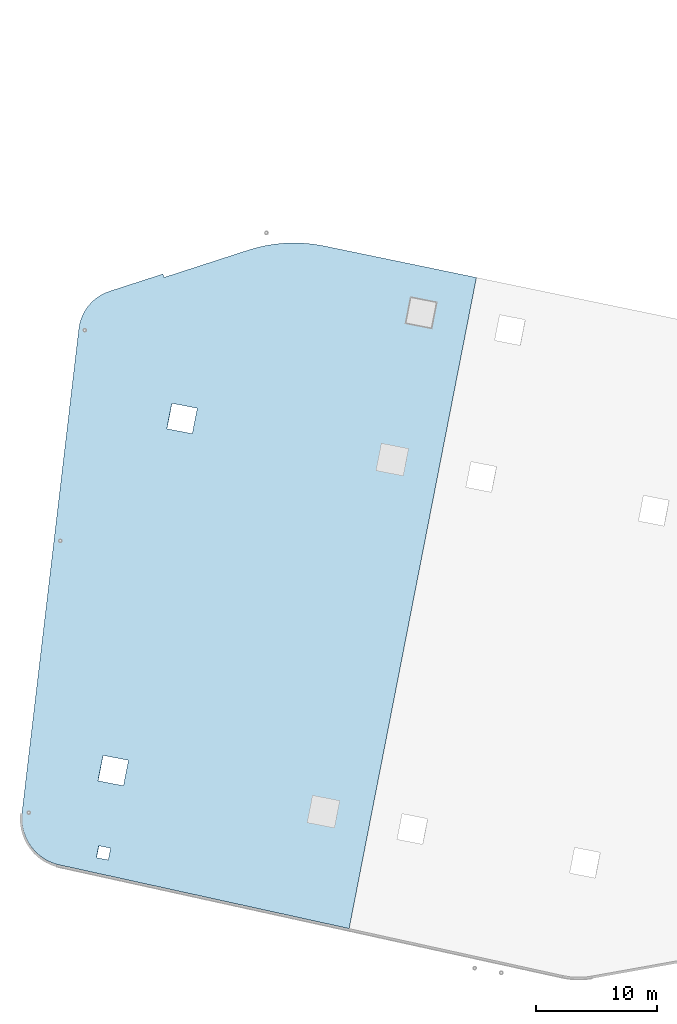
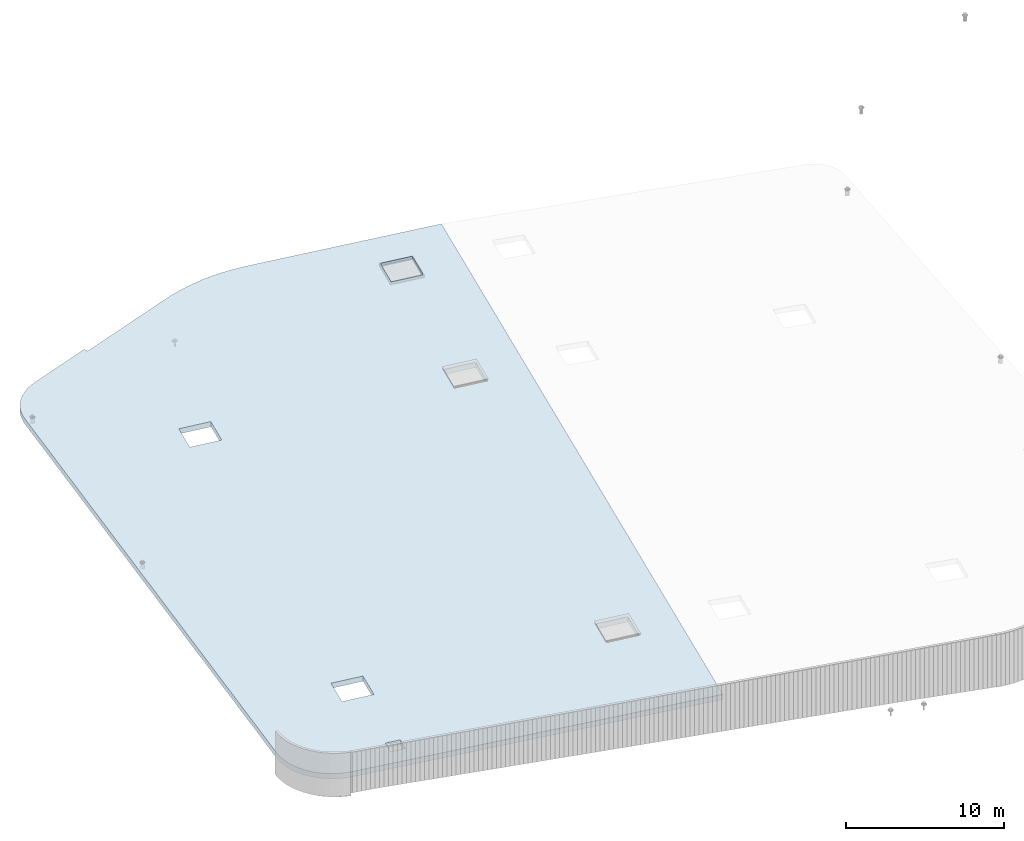
# One storey, part 10 of 18: 1 roof.
"""IFC2X3 building model written with IfcOpenShell, lengths in centimetres."""

from ifc_helpers import new_model, entity, si_unit, converted_unit, derived_unit, direction, frame, origin, place, context, subcontext, project, spatial, faceted_brep, material, element, save


model = new_model("IFC2X3")

# Units and contexts
model_context = context("Model", 3, precision=0.001, world=origin(), true_north=direction((6.12303176911189e-17, 1.0)))
body_context = subcontext(model_context, "Body", "Model", "MODEL_VIEW")
ifc_project = project(units=[si_unit("LENGTHUNIT", "METRE", prefix="CENTI"), si_unit("AREAUNIT", "SQUARE_METRE"), si_unit("VOLUMEUNIT", "CUBIC_METRE"), converted_unit("PLANEANGLEUNIT", "DEGREE", entity("IfcRatioMeasure", 0.0174532925199433), si_unit("PLANEANGLEUNIT", "RADIAN"), dimensions=[0, 0, 0, 0, 0, 0, 0]), si_unit("MASSUNIT", "GRAM", prefix="KILO"), derived_unit("MASSDENSITYUNIT", [(si_unit("MASSUNIT", "GRAM", prefix="KILO"), 1), (si_unit("LENGTHUNIT", "METRE"), -3)]), si_unit("TIMEUNIT", "SECOND"), si_unit("FREQUENCYUNIT", "HERTZ"), si_unit("THERMODYNAMICTEMPERATUREUNIT", "DEGREE_CELSIUS"), derived_unit("THERMALTRANSMITTANCEUNIT", [(si_unit("MASSUNIT", "GRAM", prefix="KILO"), 1), (si_unit("THERMODYNAMICTEMPERATUREUNIT", "KELVIN"), -1), (si_unit("TIMEUNIT", "SECOND"), -3)]), derived_unit("VOLUMETRICFLOWRATEUNIT", [(si_unit("LENGTHUNIT", "METRE"), 3), (si_unit("TIMEUNIT", "SECOND"), -1)]), si_unit("ELECTRICCURRENTUNIT", "AMPERE"), si_unit("ELECTRICVOLTAGEUNIT", "VOLT"), si_unit("POWERUNIT", "WATT"), si_unit("FORCEUNIT", "NEWTON", prefix="KILO"), si_unit("ILLUMINANCEUNIT", "LUX"), si_unit("LUMINOUSFLUXUNIT", "LUMEN"), si_unit("LUMINOUSINTENSITYUNIT", "CANDELA"), derived_unit("USERDEFINED", [(si_unit("MASSUNIT", "GRAM", prefix="KILO"), -1), (si_unit("LENGTHUNIT", "METRE"), -2), (si_unit("TIMEUNIT", "SECOND"), 3), (si_unit("LUMINOUSFLUXUNIT", "LUMEN"), 1)]), derived_unit("LINEARVELOCITYUNIT", [(si_unit("LENGTHUNIT", "METRE"), 1), (si_unit("TIMEUNIT", "SECOND"), -1)]), si_unit("PRESSUREUNIT", "PASCAL"), derived_unit("USERDEFINED", [(si_unit("LENGTHUNIT", "METRE"), -2), (si_unit("MASSUNIT", "GRAM", prefix="KILO"), 1), (si_unit("TIMEUNIT", "SECOND"), -2)])], contexts=[model_context])

# Site, building, storey
site_placement = place(None, origin())
site = spatial("IfcSite", under=ifc_project, at=site_placement, CompositionType="ELEMENT")
building_placement = place(site_placement, origin())
building = spatial("IfcBuilding", under=site, at=building_placement, CompositionType="ELEMENT")
storey_placement = place(building_placement, frame((0.0, 0.0, 1422.0)))
storey = spatial("IfcBuildingStorey", under=building, at=storey_placement, CompositionType="ELEMENT", Elevation=1422.0)

# Roof
ifc_material = material(Name="Isolation")
roof_placement = place(storey_placement, frame((3772.64149009777, 568.088631228857, -228.03667268437)))
element("IfcRoof", 1, at=roof_placement, inside=storey, material=ifc_material, ShapeType="NOTDEFINED", context=body_context, shape_type="Brep", body=[
    faceted_brep([(1172.41102121695, 5432.32896240886, 58.7458335793177), (1172.41102121695, 5432.32896240886, 18.7266181947054), (728.0387046234, 5288.32654245779, 6.06346780380066), (728.0387046234, 5288.32654245779, 46.082683188413), (474.570328481408, 4979.02535902043, 40.2107504624908), (474.570328481408, 4979.02535902043, 0.191535077878443), (3.26196134842444, 967.563739430381, 9.71114802205869), (3.26196134842444, 967.563739430381, 49.730363406671), (688.67923121018, 5273.03915534229, 44.9761307698566), (688.67923121018, 5273.03915534229, 4.95691538524426), (616.440949093956, 5229.56615969017, 43.0369083113903), (651.317791204315, 5253.36696296641, 43.9564459670626), (651.317791204315, 5253.36696296641, 3.93723058245029), (616.440949093956, 5229.56615969017, 3.01769292677792), (584.502912019572, 5201.94670748668, 2.21027771598534), (584.502912019572, 5201.94670748668, 42.2294931005975), (555.919614555912, 5170.86829925381, 41.5447154424714), (555.919614555912, 5170.86829925381, 1.52550005785906), (510.257682178185, 5099.993348209, 40.5770314248203), (531.063301924176, 5136.73567447137, 40.9914933147626), (531.063301924176, 5136.73567447137, 0.972277930150231), (510.257682178185, 5099.993348209, 0.557816040207985), (481.826060496165, 5020.6213528794, 40.1841014008908), (493.773710498476, 5061.11982212957, 40.3067273814438), (493.773710498476, 5061.11982212957, 0.287511996831686), (481.826060496165, 5020.6213528794, 0.164886016278451), (0.159527223592889, 923.993664603507, 9.87589854162768), (0.159527223592889, 923.993664603507, 49.89511392624), (1.83176668440047, 880.345295411702, 10.1863798494419), (1.83176668440047, 880.345295411702, 50.2055952340545), (8.25869356083199, 837.140305782684, 50.6580965384776), (8.25869356083199, 837.140305782684, 10.6388811538653), (19.3634948986146, 794.895070487246, 11.2279942772923), (19.3634948986146, 794.895070487246, 51.2472096619046), (35.0134490076212, 754.11449356263, 11.9466782932766), (35.0134490076212, 754.11449356263, 51.9658936778892), (55.0215117169057, 715.285973831124, 12.7863436778493), (55.0215117169057, 715.285973831124, 52.8055590624617), (79.1485518778617, 678.873579636425, 13.7369549692674), (79.1485518778617, 678.873579636425, 53.7561703538797), (107.106209397362, 645.312502419791, 14.7871507092382), (107.106209397362, 645.312502419791, 54.8063660938507), (138.560341642405, 615.003855425412, 15.9243792321055), (138.560341642405, 615.003855425412, 55.9435946167181), (173.135017025738, 588.309879699496, 57.1542640636963), (173.135017025738, 588.309879699496, 17.135048679084), (210.417008042168, 565.549614679743, 18.4046894446135), (210.417008042168, 565.549614679743, 58.4239048292258), (249.960730055961, 546.995085119164, 19.71812711331), (249.960730055961, 546.995085119164, 59.7373424979223), (291.29356681223, 532.868049917163, 21.0596638206225), (291.293566812225, 532.868049917165, 61.0788792052346), (2717.25563611563, 0.0, 98.0366726843696), (2717.25563611563, 0.0, 138.055888068982), (719.990010163838, 569.47251861807, 33.8846546784835), (2379.97372166035, 885.166473519297, 82.5105212240978), (2590.87822389998, 843.936492209236, 89.1723209979762), (2632.12801145632, 1054.94230972747, 89.172321076922), (3162.00078632684, 3765.41052461211, 89.1723220910162), (3773.44722783591, 5402.75714103302, 98.0366726843696), (621.894892335105, 588.649251512666, 30.7861431557493), (641.080837438541, 686.791492726574, 30.7861431104313), (634.908026171703, 1226.31132729335, 27.3894693182454), (676.157813728053, 1437.31714481162, 27.3894693971912), (1206.03058859856, 4147.78535969624, 27.3894704112857), (1247.28037615491, 4358.79117721449, 27.3894704902312), (1181.68676131111, 5403.71578974116, 19.1790051379819), (1458.18487839454, 4317.56119590444, 34.0512702641099), (1881.75180857121, 5630.66096295928, 39.1280614567962), (1953.31622743025, 5651.47519289758, 41.1815484946758), (2026.01477795881, 5667.89527102167, 43.2956753100137), (2099.57792005694, 5679.86031758268, 45.4626034803239), (2173.7329080298, 5687.3259704878, 47.6742988146708), (2210.94648333696, 5689.36221945559, 48.7943772707569), (2285.47332039095, 5690.03212488482, 51.0578044595634), (2359.90276997972, 5686.16492325208, 53.3452538179007), (2433.95887445161, 5677.77495275128, 55.6482443055794), (2507.36706038447, 5664.89332037797, 57.9582372614868), (2992.34607164356, 4017.64632344043, 82.5105223960834), (2951.09628408721, 3806.64050592215, 82.5105223171378), (3203.25057388319, 3976.41634213039, 89.172322169962), (2421.2235092167, 1096.17229103755, 82.5105213030434), (1416.93509083819, 4106.55537838618, 34.0512701851641), (887.062315967685, 1396.08716350159, 34.0512691710699), (845.812528411335, 1185.0813459833, 34.0512690921241), (739.175955267266, 667.614759831952, 33.8846546331655), (2378.75734220275, 885.404265024969, 122.491315065828), (718.773630706238, 569.710310123749, 73.865448520214), (2589.66184444238, 844.174283714913, 129.153114839707), (737.959575809675, 667.852551337666, 73.8654484748958), (844.596148953732, 1185.31913748896, 74.0320629338546), (885.845936510088, 1396.32495500727, 74.0320630128004), (2420.0071297591, 1096.41008254323, 122.491315144774), (1415.7187113806, 4106.79316989189, 74.0320640268946), (2949.87990462961, 3806.87829742785, 122.491316158868), (3160.78440686924, 3765.6483161178, 129.153115932747), (2630.91163199874, 1055.18010123321, 129.153114918652), (3773.44722783591, 5402.75714103302, 138.055888068982), (3202.03419442559, 3976.65413363608, 129.153116011693), (1456.96849893694, 4317.79898741015, 74.0320641058401), (2991.12969218596, 4017.88411494613, 122.491316237814), (3188.12824702146, 5025.59454390771, 122.491316614838), (2359.90276997972, 5686.16492325208, 93.3644692025131), (2285.47332039095, 5690.03212488482, 91.0770198441758), (2210.94648333696, 5689.36221945559, 88.8135926553692), (2173.7329080298, 5687.3259704878, 87.6935141992832), (2099.57792005694, 5679.86031758268, 85.4818188649362), (2026.01477795881, 5667.89527102167, 83.3148906946261), (1953.31622743025, 5651.47519289758, 81.2007638792882), (1881.7518085712, 5630.66096295928, 79.1472768414081), (1181.68676131111, 5403.71578974116, 59.1982205225943), (1246.06399669731, 4359.02896872017, 67.3702643319617), (674.941434270456, 1437.55493631732, 67.3702632389217), (1204.81420914096, 4148.02315120191, 67.3702642530162), (633.691646714106, 1226.54911879903, 67.3702631599761), (639.864457980945, 687.02928423227, 70.7669369521618), (620.678512877511, 588.887043018363, 70.7669369974798), (3399.03274926109, 4984.36456259765, 129.153116388717), (3440.28253681744, 5195.37038011594, 129.153116467663), (3229.37803457781, 5236.60036142601, 122.491316693784), (2507.36706038448, 5664.89332037796, 97.9774526460996), (2433.95887445161, 5677.77495275128, 95.6674596901917), (3188.88848418245, 5025.44592421665, 97.5033204637572), (3230.1382717388, 5236.45174173492, 97.5033205427029), (3441.04277397844, 5195.22176042488, 104.165120316582), (3399.79298642209, 4984.21594290661, 104.165120237636)], [[[0, 1, 2, 3]], [[4, 5, 6, 7]], [[8, 3, 2, 9]], [[10, 11, 12, 13]], [[9, 12, 11, 8]], [[13, 14, 15, 10]], [[16, 15, 14, 17]], [[18, 19, 20, 21]], [[22, 23, 24, 25]], [[21, 24, 23, 18]], [[25, 5, 4, 22]], [[20, 19, 16, 17]], [[7, 6, 26, 27]], [[28, 29, 27, 26]], [[30, 31, 32, 33]], [[32, 34, 35, 33]], [[31, 30, 29, 28]], [[35, 34, 36, 37]], [[36, 38, 39, 37]], [[39, 38, 40, 41]], [[42, 43, 41, 40]], [[44, 45, 46, 47]], [[46, 48, 49, 47]], [[45, 44, 43, 42]], [[49, 48, 50, 51]], [[51, 50, 52, 53]], [[52, 54, 55]], [[55, 56, 52]], [[57, 52, 56]], [[50, 54, 52]], [[57, 58, 52]], [[59, 52, 58]], [[60, 54, 50]], [[61, 60, 50]], [[48, 61, 50]], [[48, 46, 61]], [[45, 61, 46]], [[61, 45, 42]], [[61, 42, 40]], [[61, 40, 38]], [[36, 61, 38]], [[34, 61, 36]], [[61, 34, 32]], [[32, 31, 61]], [[31, 28, 61]], [[26, 61, 28]], [[6, 61, 26]], [[6, 62, 61]], [[6, 63, 62]], [[5, 63, 6]], [[5, 64, 63]], [[64, 5, 65]], [[2, 65, 5]], [[2, 5, 9]], [[9, 5, 12]], [[5, 13, 12]], [[13, 5, 14]], [[14, 5, 17]], [[20, 17, 5]], [[21, 20, 5]], [[5, 24, 21]], [[24, 5, 25]], [[66, 65, 2]], [[2, 1, 66]], [[67, 65, 66]], [[66, 68, 67]], [[69, 67, 68]], [[67, 69, 70]], [[71, 67, 70]], [[67, 71, 72]], [[67, 72, 73]], [[67, 73, 74]], [[74, 75, 67]], [[76, 67, 75]], [[76, 77, 67]], [[77, 78, 67]], [[59, 78, 77]], [[78, 79, 67]], [[59, 80, 78]], [[81, 79, 58]], [[79, 81, 82]], [[79, 82, 67]], [[63, 64, 82]], [[82, 83, 63]], [[82, 81, 83]], [[83, 81, 55]], [[55, 84, 83]], [[62, 84, 61]], [[84, 85, 61]], [[55, 54, 85]], [[55, 85, 84]], [[58, 57, 81]], [[59, 58, 80]], [[86, 87, 53]], [[53, 88, 86]], [[89, 87, 86]], [[90, 89, 86]], [[86, 91, 90]], [[86, 92, 91]], [[92, 93, 91]], [[92, 94, 93]], [[95, 94, 92]], [[92, 96, 95]], [[88, 53, 96]], [[96, 53, 95]], [[53, 97, 95]], [[98, 95, 97]], [[93, 94, 99]], [[100, 99, 94]], [[101, 100, 98]], [[101, 99, 100]], [[99, 101, 102]], [[99, 102, 103]], [[103, 104, 99]], [[99, 104, 105]], [[105, 106, 99]], [[99, 106, 107]], [[99, 107, 108]], [[99, 108, 109]], [[110, 99, 109]], [[111, 99, 110]], [[91, 93, 112]], [[93, 113, 112]], [[112, 113, 4]], [[111, 4, 113]], [[7, 112, 4]], [[3, 4, 111]], [[8, 4, 3]], [[8, 11, 4]], [[10, 4, 11]], [[15, 4, 10]], [[4, 15, 16]], [[4, 16, 19]], [[4, 19, 18]], [[18, 23, 4]], [[22, 4, 23]], [[7, 114, 112]], [[115, 114, 7]], [[27, 115, 7]], [[29, 115, 27]], [[115, 29, 30]], [[115, 30, 33]], [[35, 115, 33]], [[37, 115, 35]], [[37, 39, 115]], [[39, 41, 115]], [[41, 43, 115]], [[115, 43, 44]], [[115, 44, 47]], [[47, 49, 115]], [[51, 115, 49]], [[53, 87, 51]], [[51, 116, 115]], [[51, 87, 116]], [[115, 89, 90]], [[115, 90, 114]], [[117, 98, 97]], [[117, 97, 118]], [[119, 118, 97]], [[120, 119, 97]], [[120, 101, 119]], [[101, 120, 121]], [[121, 102, 101]], [[101, 98, 117]], [[3, 110, 0]], [[111, 110, 3]], [[53, 52, 59, 97]], [[55, 81, 92, 86]], [[78, 100, 94, 79]], [[101, 122, 123, 119]], [[55, 86, 88, 56]], [[57, 56, 88, 96]], [[58, 95, 98, 80]], [[117, 118, 124, 125]], [[81, 57, 96, 92]], [[63, 112, 114, 62]], [[65, 111, 113, 64]], [[84, 62, 114, 90]], [[83, 84, 90, 91]], [[82, 93, 99, 67]], [[63, 83, 91, 112]], [[64, 113, 93, 82]], [[67, 99, 111, 65]], [[58, 79, 94, 95]], [[80, 98, 100, 78]], [[125, 124, 123, 122]], [[101, 117, 125, 122]], [[119, 123, 124, 118]], [[61, 115, 116, 60]], [[54, 60, 116, 87]], [[54, 87, 89, 85]], [[85, 89, 115, 61]], [[110, 66, 1, 0]], [[109, 68, 66, 110]], [[97, 59, 77, 120]], [[121, 120, 77, 76]], [[103, 102, 75, 74]], [[76, 75, 102, 121]], [[74, 73, 104, 103]], [[73, 72, 105, 104]], [[106, 105, 72, 71]], [[108, 107, 70, 69]], [[71, 70, 107, 106]], [[69, 68, 109, 108]]]),
])

save(model, "model.ifc")
